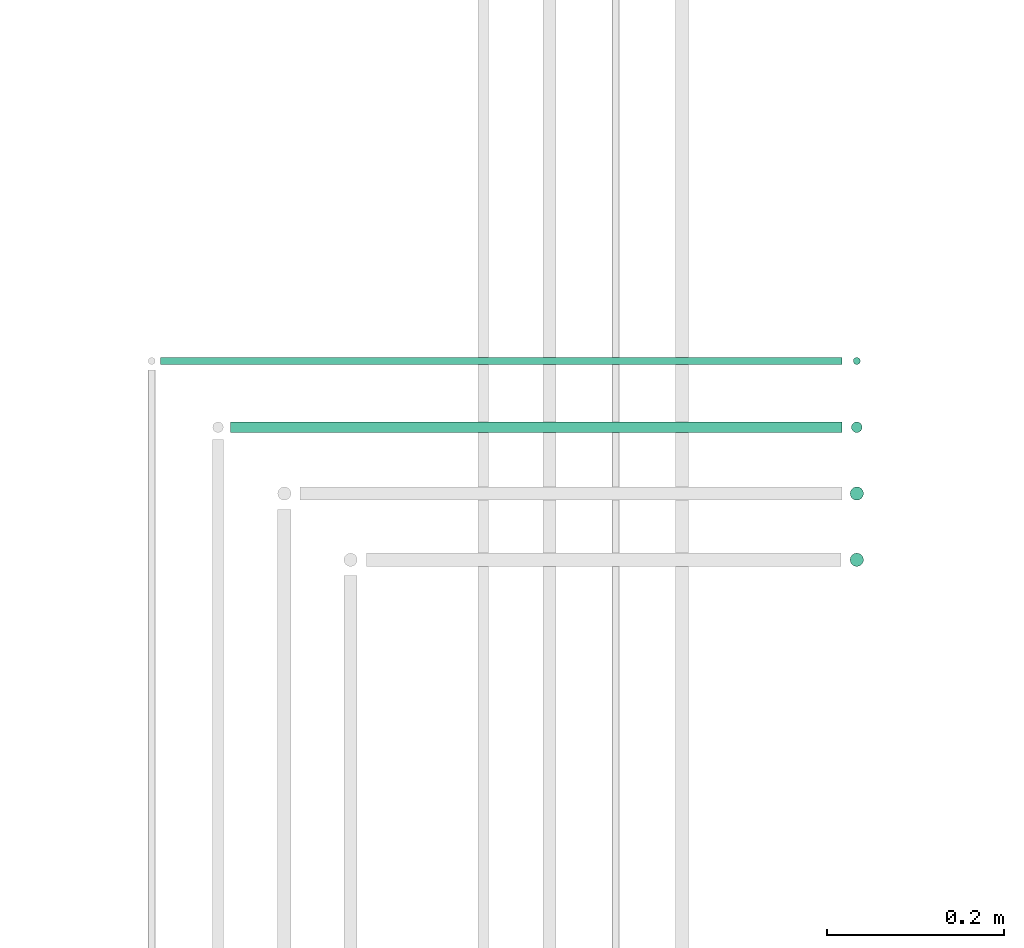
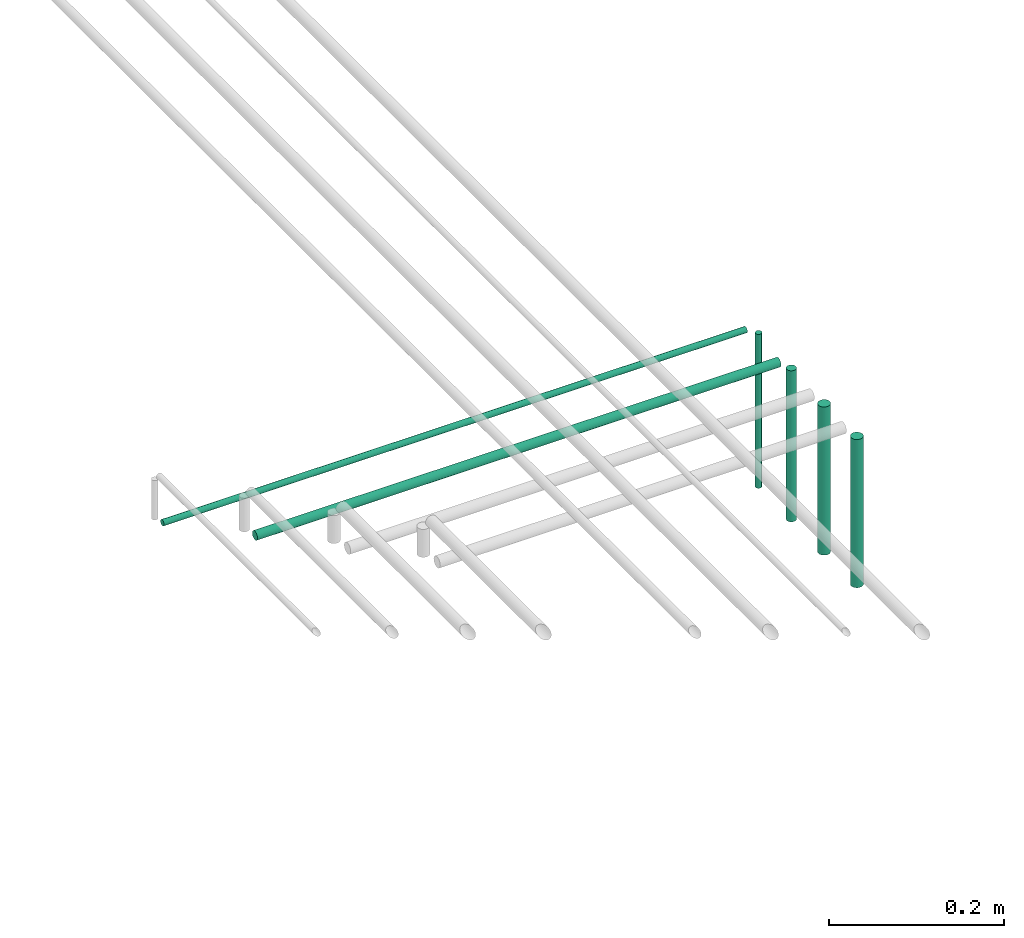
# One storey, part 33 of 65: 6 flow segments.
"""IFC2X3 building model written with IfcOpenShell, lengths in millimetres."""

from ifc_helpers import new_model, entity, si_unit, converted_unit, derived_unit, direction, frame, frame_2d, origin, origin_2d_with_axis, place, context, subcontext, project, spatial, circle, extrude, type_object, element, save


model = new_model("IFC2X3")

# Units and contexts
model_context = context("Model", 3, precision=0.01, world=origin(), true_north=direction((6.12303176911189e-17, 1.0)))
body_context = subcontext(model_context, "Body", "Model", "MODEL_VIEW")
ifc_project = project(units=[si_unit("LENGTHUNIT", "METRE", prefix="MILLI"), si_unit("AREAUNIT", "SQUARE_METRE"), si_unit("VOLUMEUNIT", "CUBIC_METRE"), converted_unit("PLANEANGLEUNIT", "DEGREE", entity("IfcRatioMeasure", 0.0174532925199433), si_unit("PLANEANGLEUNIT", "RADIAN"), dimensions=[0, 0, 0, 0, 0, 0, 0]), si_unit("MASSUNIT", "GRAM", prefix="KILO"), derived_unit("MASSDENSITYUNIT", [(si_unit("MASSUNIT", "GRAM", prefix="KILO"), 1), (si_unit("LENGTHUNIT", "METRE"), -3)]), derived_unit("MOMENTOFINERTIAUNIT", [(si_unit("LENGTHUNIT", "METRE"), 4)]), si_unit("TIMEUNIT", "SECOND"), si_unit("FREQUENCYUNIT", "HERTZ"), si_unit("THERMODYNAMICTEMPERATUREUNIT", "DEGREE_CELSIUS"), derived_unit("THERMALTRANSMITTANCEUNIT", [(si_unit("MASSUNIT", "GRAM", prefix="KILO"), 1), (si_unit("THERMODYNAMICTEMPERATUREUNIT", "KELVIN"), -1), (si_unit("TIMEUNIT", "SECOND"), -3)]), derived_unit("VOLUMETRICFLOWRATEUNIT", [(si_unit("LENGTHUNIT", "METRE"), 3), (si_unit("TIMEUNIT", "SECOND"), -1)]), derived_unit("MASSFLOWRATEUNIT", [(si_unit("MASSUNIT", "GRAM", prefix="KILO"), 1), (si_unit("TIMEUNIT", "SECOND"), -1)]), derived_unit("ROTATIONALFREQUENCYUNIT", [(si_unit("TIMEUNIT", "SECOND"), -1)]), si_unit("ELECTRICCURRENTUNIT", "AMPERE"), si_unit("ELECTRICVOLTAGEUNIT", "VOLT"), si_unit("POWERUNIT", "WATT"), si_unit("FORCEUNIT", "NEWTON", prefix="KILO"), si_unit("ILLUMINANCEUNIT", "LUX"), si_unit("LUMINOUSFLUXUNIT", "LUMEN"), si_unit("LUMINOUSINTENSITYUNIT", "CANDELA"), derived_unit("USERDEFINED", [(si_unit("MASSUNIT", "GRAM", prefix="KILO"), -1), (si_unit("LENGTHUNIT", "METRE"), -2), (si_unit("TIMEUNIT", "SECOND"), 3), (si_unit("LUMINOUSFLUXUNIT", "LUMEN"), 1)]), derived_unit("LINEARVELOCITYUNIT", [(si_unit("LENGTHUNIT", "METRE"), 1), (si_unit("TIMEUNIT", "SECOND"), -1)]), si_unit("PRESSUREUNIT", "PASCAL"), derived_unit("USERDEFINED", [(si_unit("LENGTHUNIT", "METRE"), -2), (si_unit("MASSUNIT", "GRAM", prefix="KILO"), 1), (si_unit("TIMEUNIT", "SECOND"), -2)]), derived_unit("LINEARFORCEUNIT", [(si_unit("MASSUNIT", "GRAM", prefix="KILO"), 1), (si_unit("LENGTHUNIT", "METRE"), 1), (si_unit("TIMEUNIT", "SECOND"), -2), (si_unit("LENGTHUNIT", "METRE"), -1)]), derived_unit("PLANARFORCEUNIT", [(si_unit("MASSUNIT", "GRAM", prefix="KILO"), 1), (si_unit("LENGTHUNIT", "METRE"), 1), (si_unit("TIMEUNIT", "SECOND"), -2), (si_unit("LENGTHUNIT", "METRE"), -2)])], contexts=[model_context])

# Site, building, storey
site_placement = place(None, frame((0.0, -0.00077364408347762, 0.0)))
site = spatial("IfcSite", under=ifc_project, at=site_placement, CompositionType="ELEMENT")
building_placement = place(site_placement, origin())
building = spatial("IfcBuilding", under=site, at=building_placement, CompositionType="ELEMENT")
storey_placement = place(building_placement, frame((0.0, 0.0, 19800.0)))
storey = spatial("IfcBuildingStorey", under=building, at=storey_placement, CompositionType="ELEMENT", Elevation=19800.0)

# Flow segments
pipe_segment_type = type_object("IfcPipeSegmentType", PredefinedType="NOTDEFINED")
flow_segment_1_placement = place(storey_placement, frame((38149.441725464, 10490.591292662, 2850.0)))
element("IfcFlowSegment", 1, at=flow_segment_1_placement, inside=storey, type_object=pipe_segment_type, context=body_context, shape_type="SweptSolid", body=[
    extrude(circle(Radius=7.5, at=frame_2d((0.0, -2.16573425859679e-12), x_axis=(1.0, 0.0))), frame((9.09527223591419, 9.09527223591853, 0.0)), (0.0, 0.0, 1.0), 206.999999999996),
])
flow_segment_2_placement = place(storey_placement, frame((38149.441725464, 10565.591292662, 2850.0)))
element("IfcFlowSegment", 2, at=flow_segment_2_placement, inside=storey, type_object=pipe_segment_type, context=body_context, shape_type="SweptSolid", body=[
    extrude(circle(Radius=7.5, at=frame_2d((0.0, -2.16573425859679e-12), x_axis=(1.0, 0.0))), frame((9.09527223591419, 9.09527223591853, 0.0)), (0.0, 0.0, 1.0), 207.000000000005),
])
flow_segment_3_placement = place(storey_placement, frame((37449.8041526611, 10642.091292662, 3067.40472776408)))
element("IfcFlowSegment", 3, at=flow_segment_3_placement, inside=storey, type_object=pipe_segment_type, context=body_context, shape_type="SweptSolid", body=[
    extrude(circle(Radius=6.0, at=origin_2d_with_axis()), frame((0.0, 7.59527223594919, 7.59527223591454), z_axis=(1.0, 0.0, 0.0), x_axis=(0.0, -1.0, 0.0)), (0.0, 0.0, 1.0), 691.732845038726),
])
flow_segment_4_placement = place(storey_placement, frame((38150.941725464, 10642.091292662, 2850.0)))
element("IfcFlowSegment", 4, at=flow_segment_4_placement, inside=storey, type_object=pipe_segment_type, context=body_context, shape_type="SweptSolid", body=[
    extrude(circle(Radius=6.0, at=frame_2d((0.0, -2.16573425859679e-12), x_axis=(1.0, 0.0))), frame((7.59527223591454, 7.59527223591887, 0.0)), (0.0, 0.0, 1.0), 211.000000000004),
])
flow_segment_5_placement = place(storey_placement, frame((37370.8041526611, 10719.091292662, 3069.40472776408)))
element("IfcFlowSegment", 5, at=flow_segment_5_placement, inside=storey, type_object=pipe_segment_type, context=body_context, shape_type="SweptSolid", body=[
    extrude(circle(Radius=4.0, at=origin_2d_with_axis()), frame((0.0, 5.59527223596697, 5.59527223591499), z_axis=(1.0, 0.0, 0.0), x_axis=(0.0, -1.0, 0.0)), (0.0, 0.0, 1.0), 770.732845038734),
])
flow_segment_6_placement = place(storey_placement, frame((38152.941725464, 10719.091292662, 2850.0)))
element("IfcFlowSegment", 6, at=flow_segment_6_placement, inside=storey, type_object=pipe_segment_type, context=body_context, shape_type="SweptSolid", body=[
    extrude(circle(Radius=4.0, at=origin_2d_with_axis()), frame((5.59527223591499, 5.59527223591499, 0.0)), (0.0, 0.0, 1.0), 215.000000000003),
])

save(model, "model.ifc")
